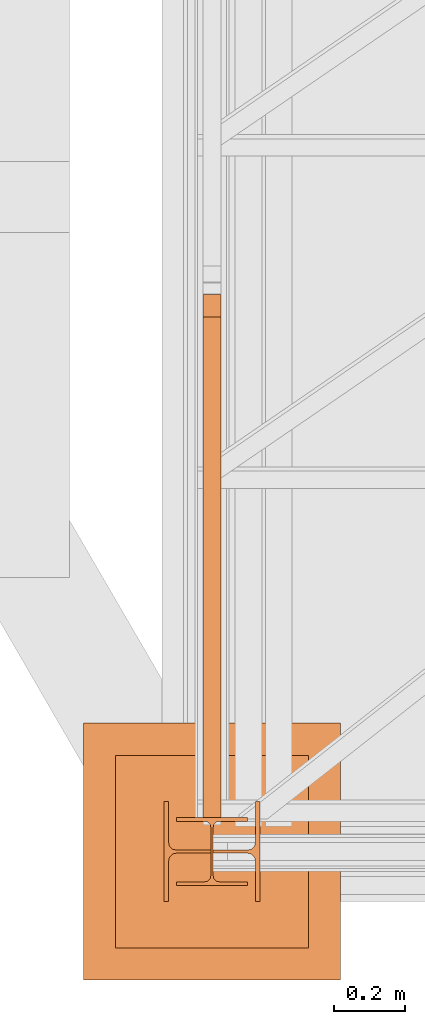
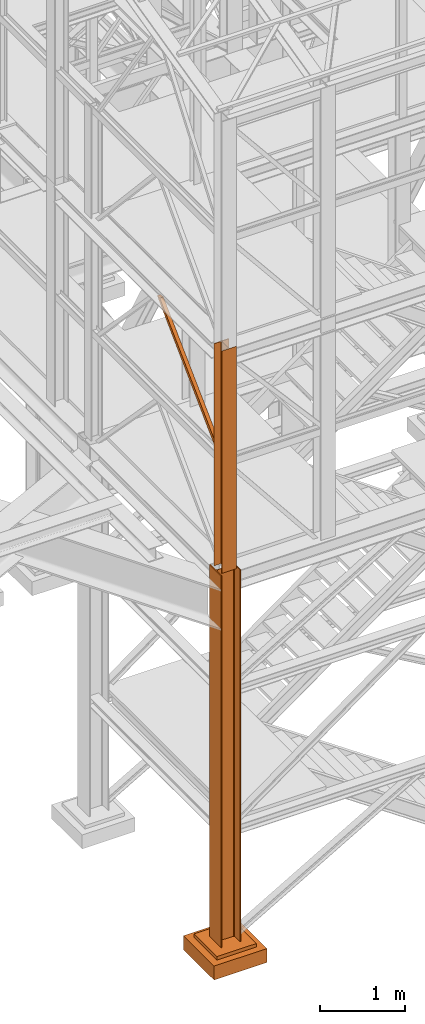
# One storey, part 2 of 208: 4 proxies.
"""IFC2X3 building model written with IfcOpenShell, lengths in millimetres."""

from ifc_helpers import new_model, entity, si_unit, converted_unit, frame, origin, origin_with_axes, place, context, subcontext, project, spatial, faceted_brep, element, save


model = new_model("IFC2X3")

# Units and contexts
model_context = context("Model", 3, precision=1e-05, world=origin())
plan_context = context("Plan", 3, precision=1e-05, world=origin())
body_context = subcontext(model_context, "Body", "Model", "MODEL_VIEW")
ifc_project = project(units=[si_unit("LENGTHUNIT", "METRE", prefix="MILLI"), converted_unit("PLANEANGLEUNIT", "DEGREE", entity("IfcPlaneAngleMeasure", 0.0174532925199433), si_unit("PLANEANGLEUNIT", "RADIAN"), dimensions=[0, 0, 0, 0, 0, 0, 0]), si_unit("AREAUNIT", "SQUARE_METRE"), si_unit("VOLUMEUNIT", "CUBIC_METRE")], contexts=[model_context, plan_context])

# Building, storey
building_placement = place(None, origin())
building = spatial("IfcBuilding", under=ifc_project, at=building_placement, CompositionType="COMPLEX")
storey_placement = place(building_placement, origin_with_axes())
storey = spatial("IfcBuildingStorey", under=building, at=storey_placement, Name="Geschoss", CompositionType="ELEMENT")

# Proxies
proxy_1_placement = place(storey_placement, frame((1173.25497001878, -25077.57437538435, 6812.489999254944), z_axis=(0.0, 0.0, 1.0), x_axis=(1.0, 0.0, 0.0)))
element("IfcBuildingElementProxy", 1, at=proxy_1_placement, inside=storey, context=body_context, shape_type="Brep", body=[
    faceted_brep([(50.01000074505896, 0.00999999999839929, 71.50990716364959), (0.0100000000009004, 0.00999999999839929, 71.50990716364777), (0.009999999999990905, 1404.126463695789, 1442.509998658892), (50.01000074505805, 1404.126463695789, 1442.509998658892), (50.01000074505896, 7.230990578147612, 0.1025547097015078), (50.01000074505896, 0.00999999999839929, 0.009999999999308784), (50.01000074505896, 0.00999999999839929, 71.50990716364959), (50.01000074505805, 1404.126463695789, 1442.509998658892), (50.01000074505805, 1467.509985364493, 1442.509998658892), (0.0100000000009004, 7.230990578147612, 0.1025547097015078), (50.01000074505896, 7.230990578147612, 0.1025547097015078), (50.01000074505805, 1467.509985364493, 1442.509998658892), (0.009999999999990905, 1467.509985364493, 1442.50999865889), (0.0100000000009004, 0.00999999999839929, 71.50990716364777), (0.0100000000009004, 0.00999999999839929, 0.009999999999308784), (0.0100000000009004, 7.230990578147612, 0.1025547097015078), (0.009999999999990905, 1467.509985364493, 1442.50999865889), (0.009999999999990905, 1404.126463695789, 1442.509998658892), (0.0100000000009004, 0.00999999999839929, 0.009999999999308784), (50.01000074505896, 0.00999999999839929, 0.009999999999308784), (50.01000074505896, 7.230990578147612, 0.1025547097015078), (0.0100000000009004, 7.230990578147612, 0.1025547097015078), (0.0100000000009004, 0.00999999999839929, 71.50990716364777), (50.01000074505896, 0.00999999999839929, 71.50990716364959), (50.01000074505896, 0.00999999999839929, 0.009999999999308784), (0.0100000000009004, 0.00999999999839929, 0.009999999999308784), (50.01000074505805, 1404.126463695789, 1442.509998658892), (0.009999999999990905, 1404.126463695789, 1442.509998658892), (0.009999999999990905, 1467.509985364493, 1442.50999865889), (50.01000074505805, 1467.509985364493, 1442.509998658892)], [[[0, 1, 2, 3]], [[4, 5, 6, 7, 8]], [[9, 10, 11, 12]], [[13, 14, 15, 16, 17]], [[18, 19, 20, 21]], [[22, 23, 24, 25]], [[26, 27, 28, 29]]], orient=[[False], [False], [False], [False], [False], [False], [False]]),
])
proxy_2_placement = place(storey_placement, frame((1063.254963164248, -25312.57439091394, -65.01000000000022), z_axis=(0.0, 0.0, 1.0), x_axis=(1.0, 0.0, 0.0)))
element("IfcBuildingElementProxy", 2, at=proxy_2_placement, inside=storey, context=body_context, shape_type="Brep", body=[
    faceted_brep([(0.009999999999990905, 0.01000000000203727, 5350.010005364416), (0.009999999999990905, 280.0100011920986, 5350.010005364416), (13.00999654293059, 280.0100011920986, 5350.010005364416), (13.00999654293059, 168.0100014603195, 5350.010005364416), (15.49606157302856, 155.5889206177053, 5350.010005364416), (24.58892149686812, 146.4960648848173, 5350.010005364416), (37.01000047683715, 144.0100007860419, 5350.010005364416), (233.010010251998, 144.0100007860419, 5350.010005364416), (245.431089231967, 146.4960648848173, 5350.010005364416), (254.5239491558066, 155.5889206177053, 5350.010005364416), (257.0100141859045, 168.0100014603195, 5350.010005364416), (257.0100141859045, 280.0100011920986, 5350.010005364416), (270.0100107288351, 280.0100011920986, 5350.010005364416), (270.0100107288351, 0.01000000000203727, 5350.010005364416), (257.0100141859045, 0.01000000000203727, 5350.010005364416), (257.0100141859045, 112.0099997317848, 5350.010005364416), (254.5239491558066, 124.431080574399, 5350.010005364416), (245.431089231967, 133.5239363072869, 5350.010005364416), (233.010010251998, 136.0100004060623, 5350.010005364416), (37.01000047683715, 136.0100004060623, 5350.010005364416), (24.58892149686812, 133.5239363072869, 5350.010005364416), (15.49606157302856, 124.431080574399, 5350.010005364416), (13.00999654293059, 112.0099997317848, 5350.010005364416), (13.00999654293059, 0.01000000000203727, 5350.010005364416), (0.009999999999990905, 280.0100011920986, 5350.010005364416), (0.009999999999990905, 0.01000000000203727, 5350.010005364416), (0.009999999999990905, 0.01000000000203727, 0.0100000000002467), (0.009999999999990905, 280.0100011920986, 0.0100000000002467), (13.00999654293059, 280.0100011920986, 5350.010005364416), (0.009999999999990905, 280.0100011920986, 5350.010005364416), (0.009999999999990905, 280.0100011920986, 0.0100000000002467), (13.00999654293059, 280.0100011920986, 0.0100000000002467), (13.00999654293059, 168.0100014603195, 5350.010005364416), (13.00999654293059, 280.0100011920986, 5350.010005364416), (13.00999654293059, 280.0100011920986, 0.0100000000002467), (13.00999654293059, 168.0100014603195, 0.0100000000002467), (15.49606157302856, 155.5889206177053, 5350.010005364416), (13.00999654293059, 168.0100014603195, 5350.010005364416), (13.00999654293059, 168.0100014603195, 0.0100000000002467), (15.49606157302856, 155.5889206177053, 0.0100000000002467), (24.58892149686812, 146.4960648848173, 5350.010005364416), (15.49606157302856, 155.5889206177053, 5350.010005364416), (15.49606157302856, 155.5889206177053, 0.0100000000002467), (24.58892149686812, 146.4960648848173, 0.0100000000002467), (37.01000047683715, 144.0100007860419, 5350.010005364416), (24.58892149686812, 146.4960648848173, 5350.010005364416), (24.58892149686812, 146.4960648848173, 0.0100000000002467), (37.01000047683715, 144.0100007860419, 0.0100000000002467), (233.010010251998, 144.0100007860419, 5350.010005364416), (37.01000047683715, 144.0100007860419, 5350.010005364416), (37.01000047683715, 144.0100007860419, 0.0100000000002467), (233.010010251998, 144.0100007860419, 0.0100000000002467), (245.431089231967, 146.4960648848173, 5350.010005364416), (233.010010251998, 144.0100007860419, 5350.010005364416), (233.010010251998, 144.0100007860419, 0.0100000000002467), (245.431089231967, 146.4960648848173, 0.0100000000002467), (254.5239491558066, 155.5889206177053, 5350.010005364416), (245.431089231967, 146.4960648848173, 5350.010005364416), (245.431089231967, 146.4960648848173, 0.0100000000002467), (254.5239491558066, 155.5889206177053, 0.0100000000002467), (257.0100141859045, 168.0100014603195, 5350.010005364416), (254.5239491558066, 155.5889206177053, 5350.010005364416), (254.5239491558066, 155.5889206177053, 0.0100000000002467), (257.0100141859045, 168.0100014603195, 0.0100000000002467), (257.0100141859045, 280.0100011920986, 5350.010005364416), (257.0100141859045, 168.0100014603195, 5350.010005364416), (257.0100141859045, 168.0100014603195, 0.0100000000002467), (257.0100141859045, 280.0100011920986, 0.0100000000002467), (270.0100107288351, 280.0100011920986, 5350.010005364416), (257.0100141859045, 280.0100011920986, 5350.010005364416), (257.0100141859045, 280.0100011920986, 0.0100000000002467), (270.0100107288351, 280.0100011920986, 0.0100000000002467), (270.0100107288351, 0.01000000000203727, 5350.010005364416), (270.0100107288351, 280.0100011920986, 5350.010005364416), (270.0100107288351, 280.0100011920986, 0.0100000000002467), (270.0100107288351, 0.01000000000203727, 0.0100000000002467), (257.0100141859045, 0.01000000000203727, 5350.010005364416), (270.0100107288351, 0.01000000000203727, 5350.010005364416), (270.0100107288351, 0.01000000000203727, 0.0100000000002467), (257.0100141859045, 0.01000000000203727, 0.0100000000002467), (257.0100141859045, 112.0099997317848, 5350.010005364416), (257.0100141859045, 0.01000000000203727, 5350.010005364416), (257.0100141859045, 0.01000000000203727, 0.0100000000002467), (257.0100141859045, 112.0099997317848, 0.0100000000002467), (254.5239491558066, 124.431080574399, 5350.010005364416), (257.0100141859045, 112.0099997317848, 5350.010005364416), (257.0100141859045, 112.0099997317848, 0.0100000000002467), (254.5239491558066, 124.431080574399, 0.0100000000002467), (245.431089231967, 133.5239363072869, 5350.010005364416), (254.5239491558066, 124.431080574399, 5350.010005364416), (254.5239491558066, 124.431080574399, 0.0100000000002467), (245.431089231967, 133.5239363072869, 0.0100000000002467), (233.010010251998, 136.0100004060623, 5350.010005364416), (245.431089231967, 133.5239363072869, 5350.010005364416), (245.431089231967, 133.5239363072869, 0.0100000000002467), (233.010010251998, 136.0100004060623, 0.0100000000002467), (37.01000047683715, 136.0100004060623, 5350.010005364416), (233.010010251998, 136.0100004060623, 5350.010005364416), (233.010010251998, 136.0100004060623, 0.0100000000002467), (37.01000047683715, 136.0100004060623, 0.0100000000002467), (24.58892149686812, 133.5239363072869, 5350.010005364416), (37.01000047683715, 136.0100004060623, 5350.010005364416), (37.01000047683715, 136.0100004060623, 0.0100000000002467), (24.58892149686812, 133.5239363072869, 0.0100000000002467), (15.49606157302856, 124.431080574399, 5350.010005364416), (24.58892149686812, 133.5239363072869, 5350.010005364416), (24.58892149686812, 133.5239363072869, 0.0100000000002467), (15.49606157302856, 124.431080574399, 0.0100000000002467), (13.00999654293059, 112.0099997317848, 5350.010005364416), (15.49606157302856, 124.431080574399, 5350.010005364416), (15.49606157302856, 124.431080574399, 0.0100000000002467), (13.00999654293059, 112.0099997317848, 0.0100000000002467), (13.00999654293059, 0.01000000000203727, 5350.010005364416), (13.00999654293059, 112.0099997317848, 5350.010005364416), (13.00999654293059, 112.0099997317848, 0.0100000000002467), (13.00999654293059, 0.01000000000203727, 0.0100000000002467), (0.009999999999990905, 0.01000000000203727, 5350.010005364416), (13.00999654293059, 0.01000000000203727, 5350.010005364416), (13.00999654293059, 0.01000000000203727, 0.0100000000002467), (0.009999999999990905, 0.01000000000203727, 0.0100000000002467), (0.009999999999990905, 0.01000000000203727, 0.0100000000002467), (13.00999654293059, 0.01000000000203727, 0.0100000000002467), (13.00999654293059, 112.0099997317848, 0.0100000000002467), (15.49606157302856, 124.431080574399, 0.0100000000002467), (24.58892149686812, 133.5239363072869, 0.0100000000002467), (37.01000047683715, 136.0100004060623, 0.0100000000002467), (233.010010251998, 136.0100004060623, 0.0100000000002467), (245.431089231967, 133.5239363072869, 0.0100000000002467), (254.5239491558066, 124.431080574399, 0.0100000000002467), (257.0100141859045, 112.0099997317848, 0.0100000000002467), (257.0100141859045, 0.01000000000203727, 0.0100000000002467), (270.0100107288351, 0.01000000000203727, 0.0100000000002467), (270.0100107288351, 280.0100011920986, 0.0100000000002467), (257.0100141859045, 280.0100011920986, 0.0100000000002467), (257.0100141859045, 168.0100014603195, 0.0100000000002467), (254.5239491558066, 155.5889206177053, 0.0100000000002467), (245.431089231967, 146.4960648848173, 0.0100000000002467), (233.010010251998, 144.0100007860419, 0.0100000000002467), (37.01000047683715, 144.0100007860419, 0.0100000000002467), (24.58892149686812, 146.4960648848173, 0.0100000000002467), (15.49606157302856, 155.5889206177053, 0.0100000000002467), (13.00999654293059, 168.0100014603195, 0.0100000000002467), (13.00999654293059, 280.0100011920986, 0.0100000000002467), (0.009999999999990905, 280.0100011920986, 0.0100000000002467)], [[[0, 1, 2, 3, 4, 5, 6, 7, 8, 9, 10, 11, 12, 13, 14, 15, 16, 17, 18, 19, 20, 21, 22, 23]], [[24, 25, 26, 27]], [[28, 29, 30, 31]], [[32, 33, 34, 35]], [[36, 37, 38, 39]], [[40, 41, 42, 43]], [[44, 45, 46, 47]], [[48, 49, 50, 51]], [[52, 53, 54, 55]], [[56, 57, 58, 59]], [[60, 61, 62, 63]], [[64, 65, 66, 67]], [[68, 69, 70, 71]], [[72, 73, 74, 75]], [[76, 77, 78, 79]], [[80, 81, 82, 83]], [[84, 85, 86, 87]], [[88, 89, 90, 91]], [[92, 93, 94, 95]], [[96, 97, 98, 99]], [[100, 101, 102, 103]], [[104, 105, 106, 107]], [[108, 109, 110, 111]], [[112, 113, 114, 115]], [[116, 117, 118, 119]], [[120, 121, 122, 123, 124, 125, 126, 127, 128, 129, 130, 131, 132, 133, 134, 135, 136, 137, 138, 139, 140, 141, 142, 143]]], orient=[[False], [False], [False], [False], [False], [False], [False], [False], [False], [False], [False], [False], [False], [False], [False], [False], [False], [False], [False], [False], [False], [False], [False], [False], [False], [False]]),
])
proxy_3_placement = place(storey_placement, frame((838.254968528666, -25532.57439031788, -315.0099999999999), z_axis=(0.0, 0.0, 1.0), x_axis=(1.0, 0.0, 0.0)))
element("IfcBuildingElementProxy", 3, at=proxy_3_placement, inside=storey, context=body_context, shape_type="Brep", body=[
    faceted_brep([(630.01, 630.0099999999984, 250.01), (630.01, 90.0099999999984, 250.01), (90.00999999999999, 90.0099999999984, 250.01), (90.00999999999999, 630.0099999999984, 250.01), (630.01, 630.0099999999984, 200.01), (630.01, 90.0099999999984, 200.01), (630.01, 90.0099999999984, 250.01), (630.01, 630.0099999999984, 250.01), (90.00999999999999, 630.0099999999984, 200.01), (630.01, 630.0099999999984, 200.01), (630.01, 630.0099999999984, 250.01), (90.00999999999999, 630.0099999999984, 250.01), (90.00999999999999, 90.0099999999984, 200.01), (90.00999999999999, 630.0099999999984, 200.01), (90.00999999999999, 630.0099999999984, 250.01), (90.00999999999999, 90.0099999999984, 250.01), (630.01, 90.0099999999984, 200.01), (90.00999999999999, 90.0099999999984, 200.01), (90.00999999999999, 90.0099999999984, 250.01), (630.01, 90.0099999999984, 250.01), (720.01, 0.00999999999839929, 0.009999999999990905), (720.01, 720.0099999999984, 0.009999999999990905), (0.009999999999990905, 720.0099999999984, 0.009999999999990905), (0.009999999999990905, 0.00999999999839929, 0.009999999999990905), (720.01, 720.0099999999984, 200.01), (720.01, 0.00999999999839929, 200.01), (0.009999999999990905, 0.00999999999839929, 200.01), (0.009999999999990905, 720.0099999999984, 200.01), (90.00999999999999, 90.0099999999984, 200.01), (630.01, 90.0099999999984, 200.01), (630.01, 630.0099999999984, 200.01), (90.00999999999999, 630.0099999999984, 200.01), (720.01, 720.0099999999984, 0.009999999999990905), (720.01, 0.00999999999839929, 0.009999999999990905), (720.01, 0.00999999999839929, 200.01), (720.01, 720.0099999999984, 200.01), (0.009999999999990905, 720.0099999999984, 0.009999999999990905), (720.01, 720.0099999999984, 0.009999999999990905), (720.01, 720.0099999999984, 200.01), (0.009999999999990905, 720.0099999999984, 200.01), (0.009999999999990905, 0.00999999999839929, 0.009999999999990905), (0.009999999999990905, 720.0099999999984, 0.009999999999990905), (0.009999999999990905, 720.0099999999984, 200.01), (0.009999999999990905, 0.00999999999839929, 200.01), (720.01, 0.00999999999839929, 0.009999999999990905), (0.009999999999990905, 0.00999999999839929, 0.009999999999990905), (0.009999999999990905, 0.00999999999839929, 200.01), (720.01, 0.00999999999839929, 200.01)], [[[0, 1, 2, 3]], [[4, 5, 6, 7]], [[8, 9, 10, 11]], [[12, 13, 14, 15]], [[16, 17, 18, 19]], [[20, 21, 22, 23]], [[24, 25, 26, 27], [28, 29, 30, 31]], [[32, 33, 34, 35]], [[36, 37, 38, 39]], [[40, 41, 42, 43]], [[44, 45, 46, 47]]], orient=[[False], [False], [False], [False], [False], [False], [False, False], [False], [False], [False], [False]]),
])
proxy_4_placement = place(storey_placement, frame((1098.254967038549, -25267.57438790132, 5284.990005364416), z_axis=(0.0, 0.0, 1.0), x_axis=(1.0, 0.0, 0.0)))
element("IfcBuildingElementProxy", 4, at=proxy_4_placement, inside=storey, context=body_context, shape_type="Brep", body=[
    faceted_brep([(0.0100000000009004, 190.0100125169738, 3200.009996721741), (200.0100029802331, 190.0100125169738, 3200.009996721741), (200.0100029802331, 180.0100146031364, 3200.009996721741), (121.2600035762796, 180.0100071525558, 3200.009996721741), (111.9441915473351, 178.1454621052726, 3200.009996721741), (105.1245498640844, 171.3258190250381, 3200.009996721741), (103.2600015571723, 162.0100079274162, 3200.009996721741), (103.2600015571723, 28.00999713897545, 3200.009996721741), (105.1245498640844, 18.69418604135353, 3200.009996721741), (111.9441915473351, 11.87454296111901, 3200.009996721741), (121.2600035762796, 10.00999791383583, 3200.009996721741), (200.0100029802331, 10.00999791383583, 3200.009996721741), (200.0100029802331, 0.00999999999839929, 3200.009996721741), (0.0100000000009004, 0.00999999999839929, 3200.009996721741), (0.0100000000009004, 10.00999791383583, 3200.009996721741), (78.75999940395445, 10.00999791383583, 3200.009996721741), (88.07581143289894, 11.87454296111901, 3200.009996721741), (94.89545311614961, 18.69418604135353, 3200.009996721741), (96.7600014230618, 28.00999713897545, 3200.009996721741), (96.7600014230618, 162.0100079274162, 3200.009996721741), (94.89545311614961, 171.3258190250381, 3200.009996721741), (88.07581143289894, 178.1454621052726, 3200.009996721741), (78.75999940395445, 180.0100071525558, 3200.009996721741), (0.0100000000009004, 180.0100146031364, 3200.009996721741), (200.0100029802331, 190.0100125169738, 3200.009996721741), (0.0100000000009004, 190.0100125169738, 3200.009996721741), (0.009999999999990905, 190.0100125169738, 0.009999999999308784), (200.0100029802322, 190.0100125169738, 0.009999999999308784), (200.0100029802331, 180.0100146031364, 3200.009996721741), (200.0100029802331, 190.0100125169738, 3200.009996721741), (200.0100029802322, 190.0100125169738, 0.009999999999308784), (200.0100029802322, 180.0100146031364, 0.009999999999308784), (121.2600035762796, 180.0100071525558, 3200.009996721741), (200.0100029802331, 180.0100146031364, 3200.009996721741), (200.0100029802322, 180.0100146031364, 0.009999999999308784), (121.2600035762787, 180.0100071525558, 0.009999999999308784), (111.9441915473351, 178.1454621052726, 3200.009996721741), (121.2600035762796, 180.0100071525558, 3200.009996721741), (121.2600035762787, 180.0100071525558, 0.009999999999308784), (111.9441915473342, 178.1454621052726, 0.009999999999308784), (105.1245498640844, 171.3258190250381, 3200.009996721741), (111.9441915473351, 178.1454621052726, 3200.009996721741), (111.9441915473342, 178.1454621052726, 0.009999999999308784), (105.1245498640835, 171.3258190250381, 0.009999999999308784), (103.2600015571723, 162.0100079274162, 3200.009996721741), (105.1245498640844, 171.3258190250381, 3200.009996721741), (105.1245498640835, 171.3258190250381, 0.009999999999308784), (103.2600015571713, 162.0100079274162, 0.009999999999308784), (103.2600015571723, 28.00999713897545, 3200.009996721741), (103.2600015571723, 162.0100079274162, 3200.009996721741), (103.2600015571713, 162.0100079274162, 0.009999999999308784), (103.2600015571713, 28.00999713897545, 0.009999999999308784), (105.1245498640844, 18.69418604135353, 3200.009996721741), (103.2600015571723, 28.00999713897545, 3200.009996721741), (103.2600015571713, 28.00999713897545, 0.009999999999308784), (105.1245498640835, 18.69418604135353, 0.009999999999308784), (111.9441915473351, 11.87454296111901, 3200.009996721741), (105.1245498640844, 18.69418604135353, 3200.009996721741), (105.1245498640835, 18.69418604135353, 0.009999999999308784), (111.9441915473342, 11.87454296111901, 0.009999999999308784), (121.2600035762796, 10.00999791383583, 3200.009996721741), (111.9441915473351, 11.87454296111901, 3200.009996721741), (111.9441915473342, 11.87454296111901, 0.009999999999308784), (121.2600035762787, 10.00999791383583, 0.009999999999308784), (200.0100029802331, 10.00999791383583, 3200.009996721741), (121.2600035762796, 10.00999791383583, 3200.009996721741), (121.2600035762787, 10.00999791383583, 0.009999999999308784), (200.0100029802322, 10.00999791383583, 0.009999999999308784), (200.0100029802331, 0.00999999999839929, 3200.009996721741), (200.0100029802331, 10.00999791383583, 3200.009996721741), (200.0100029802322, 10.00999791383583, 0.009999999999308784), (200.0100029802322, 0.00999999999839929, 0.009999999999308784), (0.0100000000009004, 0.00999999999839929, 3200.009996721741), (200.0100029802331, 0.00999999999839929, 3200.009996721741), (200.0100029802322, 0.00999999999839929, 0.009999999999308784), (0.009999999999990905, 0.00999999999839929, 0.009999999999308784), (0.0100000000009004, 10.00999791383583, 3200.009996721741), (0.0100000000009004, 0.00999999999839929, 3200.009996721741), (0.009999999999990905, 0.00999999999839929, 0.009999999999308784), (0.009999999999990905, 10.00999791383583, 0.009999999999308784), (78.75999940395445, 10.00999791383583, 3200.009996721741), (0.0100000000009004, 10.00999791383583, 3200.009996721741), (0.009999999999990905, 10.00999791383583, 0.009999999999308784), (78.75999940395354, 10.00999791383583, 0.009999999999308784), (88.07581143289894, 11.87454296111901, 3200.009996721741), (78.75999940395445, 10.00999791383583, 3200.009996721741), (78.75999940395354, 10.00999791383583, 0.009999999999308784), (88.07581143289804, 11.87454296111901, 0.009999999999308784), (94.89545311614961, 18.69418604135353, 3200.009996721741), (88.07581143289894, 11.87454296111901, 3200.009996721741), (88.07581143289804, 11.87454296111901, 0.009999999999308784), (94.8954531161487, 18.69418604135353, 0.009999999999308784), (96.7600014230618, 28.00999713897545, 3200.009996721741), (94.89545311614961, 18.69418604135353, 3200.009996721741), (94.8954531161487, 18.69418604135353, 0.009999999999308784), (96.76000142306088, 28.00999713897545, 0.009999999999308784), (96.7600014230618, 162.0100079274162, 3200.009996721741), (96.7600014230618, 28.00999713897545, 3200.009996721741), (96.76000142306088, 28.00999713897545, 0.009999999999308784), (96.76000142306088, 162.0100079274162, 0.009999999999308784), (94.89545311614961, 171.3258190250381, 3200.009996721741), (96.7600014230618, 162.0100079274162, 3200.009996721741), (96.76000142306088, 162.0100079274162, 0.009999999999308784), (94.8954531161487, 171.3258190250381, 0.009999999999308784), (88.07581143289894, 178.1454621052726, 3200.009996721741), (94.89545311614961, 171.3258190250381, 3200.009996721741), (94.8954531161487, 171.3258190250381, 0.009999999999308784), (88.07581143289804, 178.1454621052726, 0.009999999999308784), (78.75999940395445, 180.0100071525558, 3200.009996721741), (88.07581143289894, 178.1454621052726, 3200.009996721741), (88.07581143289804, 178.1454621052726, 0.009999999999308784), (78.75999940395354, 180.0100071525558, 0.009999999999308784), (0.0100000000009004, 180.0100146031364, 3200.009996721741), (78.75999940395445, 180.0100071525558, 3200.009996721741), (78.75999940395354, 180.0100071525558, 0.009999999999308784), (0.009999999999990905, 180.0100146031364, 0.009999999999308784), (0.0100000000009004, 190.0100125169738, 3200.009996721741), (0.0100000000009004, 180.0100146031364, 3200.009996721741), (0.009999999999990905, 180.0100146031364, 0.009999999999308784), (0.009999999999990905, 190.0100125169738, 0.009999999999308784), (0.009999999999990905, 190.0100125169738, 0.009999999999308784), (0.009999999999990905, 180.0100146031364, 0.009999999999308784), (78.75999940395354, 180.0100071525558, 0.009999999999308784), (88.07581143289804, 178.1454621052726, 0.009999999999308784), (94.8954531161487, 171.3258190250381, 0.009999999999308784), (96.76000142306088, 162.0100079274162, 0.009999999999308784), (96.76000142306088, 28.00999713897545, 0.009999999999308784), (94.8954531161487, 18.69418604135353, 0.009999999999308784), (88.07581143289804, 11.87454296111901, 0.009999999999308784), (78.75999940395354, 10.00999791383583, 0.009999999999308784), (0.009999999999990905, 10.00999791383583, 0.009999999999308784), (0.009999999999990905, 0.00999999999839929, 0.009999999999308784), (200.0100029802322, 0.00999999999839929, 0.009999999999308784), (200.0100029802322, 10.00999791383583, 0.009999999999308784), (121.2600035762787, 10.00999791383583, 0.009999999999308784), (111.9441915473342, 11.87454296111901, 0.009999999999308784), (105.1245498640835, 18.69418604135353, 0.009999999999308784), (103.2600015571713, 28.00999713897545, 0.009999999999308784), (103.2600015571713, 162.0100079274162, 0.009999999999308784), (105.1245498640835, 171.3258190250381, 0.009999999999308784), (111.9441915473342, 178.1454621052726, 0.009999999999308784), (121.2600035762787, 180.0100071525558, 0.009999999999308784), (200.0100029802322, 180.0100146031364, 0.009999999999308784), (200.0100029802322, 190.0100125169738, 0.009999999999308784)], [[[0, 1, 2, 3, 4, 5, 6, 7, 8, 9, 10, 11, 12, 13, 14, 15, 16, 17, 18, 19, 20, 21, 22, 23]], [[24, 25, 26, 27]], [[28, 29, 30, 31]], [[32, 33, 34, 35]], [[36, 37, 38, 39]], [[40, 41, 42, 43]], [[44, 45, 46, 47]], [[48, 49, 50, 51]], [[52, 53, 54, 55]], [[56, 57, 58, 59]], [[60, 61, 62, 63]], [[64, 65, 66, 67]], [[68, 69, 70, 71]], [[72, 73, 74, 75]], [[76, 77, 78, 79]], [[80, 81, 82, 83]], [[84, 85, 86, 87]], [[88, 89, 90, 91]], [[92, 93, 94, 95]], [[96, 97, 98, 99]], [[100, 101, 102, 103]], [[104, 105, 106, 107]], [[108, 109, 110, 111]], [[112, 113, 114, 115]], [[116, 117, 118, 119]], [[120, 121, 122, 123, 124, 125, 126, 127, 128, 129, 130, 131, 132, 133, 134, 135, 136, 137, 138, 139, 140, 141, 142, 143]]], orient=[[False], [False], [False], [False], [False], [False], [False], [False], [False], [False], [False], [False], [False], [False], [False], [False], [False], [False], [False], [False], [False], [False], [False], [False], [False], [False]]),
])

save(model, "model.ifc")
